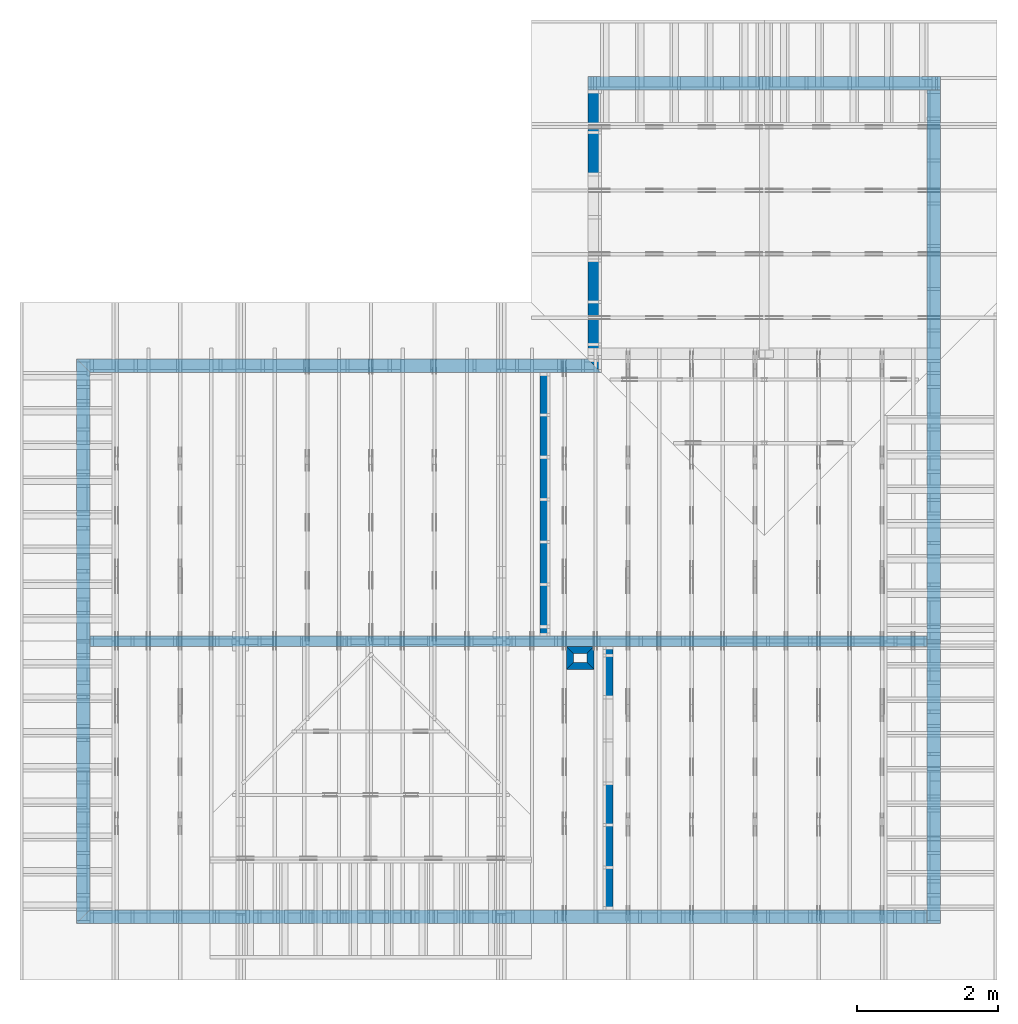
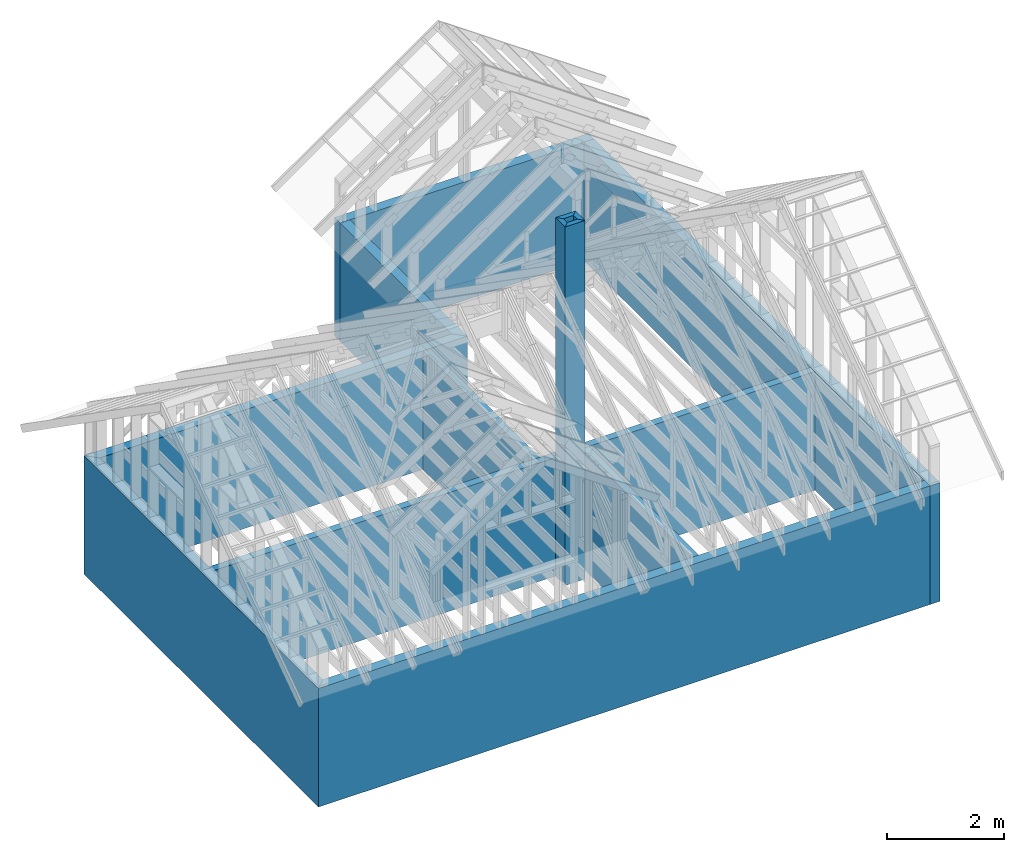
# One storey, part 1 of 70: 13 walls.
"""IFC2X3 building model written with IfcOpenShell, lengths in millimetres."""

from ifc_helpers import new_model, si_unit, frame, origin, origin_with_axes, origin_2d, place, context, project, spatial, polyline, segment, composite_curve, outline, extrude, material, layer, layer_set, layer_usage, type_object, element, save


model = new_model("IFC2X3")

# Units and contexts
model_context = context("Model", 3, precision=1e-05, world=origin())
plan_context = context("Plan", 2, precision=1e-05, world=origin_2d())
ifc_project = project(units=[si_unit("LENGTHUNIT", "METRE", prefix="MILLI"), si_unit("AREAUNIT", "SQUARE_METRE"), si_unit("VOLUMEUNIT", "CUBIC_METRE"), si_unit("SOLIDANGLEUNIT", "STERADIAN"), si_unit("PLANEANGLEUNIT", "RADIAN"), si_unit("MASSUNIT", "GRAM"), si_unit("TIMEUNIT", "SECOND"), si_unit("THERMODYNAMICTEMPERATUREUNIT", "DEGREE_CELSIUS"), si_unit("LUMINOUSINTENSITYUNIT", "LUMEN")], contexts=[model_context, plan_context])

# Site, building, storey
site_placement = place(None, origin_with_axes())
site = spatial("IfcSite", under=ifc_project, at=site_placement, CompositionType="ELEMENT")
building_placement = place(site_placement, origin_with_axes())
building = spatial("IfcBuilding", under=site, at=building_placement, Name="Layout 1", CompositionType="ELEMENT")
storey_placement = place(building_placement, origin_with_axes())
storey = spatial("IfcBuildingStorey", under=building, at=storey_placement, Name="Storey 1", CompositionType="ELEMENT", Elevation=0.0)

# Walls
ifc_material_1 = material(Name="Framing")
ifc_layer_1 = layer(ifc_material_1, 195.0)
ifc_layer_set_1 = layer_set([ifc_layer_1])
ifc_layer_usage_1 = layer_usage(ifc_layer_set_1, "AXIS2", "POSITIVE", 0.0)
wall_type_1 = type_object("IfcWallType", Name="YV195", PredefinedType="STANDARD", material=ifc_layer_set_1)
wall_1_placement = place(storey_placement, frame((-243.55339059327721, 0.0, -2470.0), z_axis=(0.0, 0.0, 1.0), x_axis=(1.0, 0.0, 0.0)))
element("IfcWallStandardCase", 1, at=wall_1_placement, inside=storey, type_object=wall_type_1, material=ifc_layer_usage_1, Name="Wall 1", context=model_context, shape_type="SweptSolid", body=[
    extrude(outline(composite_curve([segment(polyline([(195.00000000000003, 195.0), (-1.7053025658242404e-13, 2.842170943040401e-14)]), True, "CONTINUOUS"), segment(polyline([(-1.7053025658242404e-13, 2.842170943040401e-14), (12048.553390593277, 0.0)]), True, "CONTINUOUS"), segment(polyline([(12048.553390593277, 0.0), (12048.553390593277, 195.0)]), True, "CONTINUOUS"), segment(polyline([(12048.553390593277, 195.0), (195.00000000000003, 195.0)]), True, "CONTINUOUS")], self_intersect=False)), origin_with_axes(), (0.0, 0.0, 1.0), 2470.0),
])
ifc_layer_usage_2 = layer_usage(ifc_layer_set_1, "AXIS2", "POSITIVE", 0.0)
wall_2_placement = place(storey_placement, frame((12000.0, 0.0, -2470.0), z_axis=(0.0, 0.0, 1.0), x_axis=(6.123031769111886e-17, 1.0, 0.0)))
element("IfcWallStandardCase", 2, at=wall_2_placement, inside=storey, type_object=wall_type_1, material=ifc_layer_usage_2, Name="Wall 2", context=model_context, shape_type="SweptSolid", body=[
    extrude(outline(composite_curve([segment(polyline([(-1.1939911949768178e-14, 195.0), (0.0, 0.0)]), True, "CONTINUOUS"), segment(polyline([(0.0, 0.0), (11805.0, 7.228239003436582e-13)]), True, "CONTINUOUS"), segment(polyline([(11805.0, 7.228239003436582e-13), (11805.0, 195.0000000000007)]), True, "CONTINUOUS"), segment(polyline([(11805.0, 195.0000000000007), (-1.1939911949768178e-14, 195.0)]), True, "CONTINUOUS")], self_intersect=False)), origin_with_axes(), (0.0, 0.0, 1.0), 2470.0),
])
ifc_layer_usage_3 = layer_usage(ifc_layer_set_1, "AXIS2", "POSITIVE", 0.0)
wall_3_placement = place(storey_placement, frame((7000.0, 8000.0, -2470.0), z_axis=(0.0, 0.0, 1.0), x_axis=(-1.0, 1.2246063538223773e-16, 0.0)))
element("IfcWallStandardCase", 3, at=wall_3_placement, inside=storey, type_object=wall_type_1, material=ifc_layer_usage_3, Name="Wall 3", context=model_context, shape_type="SweptSolid", body=[
    extrude(outline(composite_curve([segment(polyline([(-194.99999999999912, 194.99999999999997), (9.094947017729282e-13, 1.113772990558916e-28)]), True, "CONTINUOUS"), segment(polyline([(9.094947017729282e-13, 1.113772990558916e-28), (7243.553390593276, -2.244455113571328e-14)]), True, "CONTINUOUS"), segment(polyline([(7243.553390593276, -2.244455113571328e-14), (7048.553390593276, 194.99999999999994)]), True, "CONTINUOUS"), segment(polyline([(7048.553390593276, 194.99999999999994), (-194.99999999999912, 194.99999999999997)]), True, "CONTINUOUS")], self_intersect=False)), origin_with_axes(), (0.0, 0.0, 1.0), 2470.0),
])
ifc_layer_usage_4 = layer_usage(ifc_layer_set_1, "AXIS2", "POSITIVE", 0.0)
wall_4_placement = place(storey_placement, frame((-243.55339059327576, 8000.0, -2470.0), z_axis=(0.0, 0.0, 1.0), x_axis=(-1.836909530733566e-16, -1.0, 0.0)))
element("IfcWallStandardCase", 4, at=wall_4_placement, inside=storey, type_object=wall_type_1, material=ifc_layer_usage_4, Name="Wall 4", context=model_context, shape_type="SweptSolid", body=[
    extrude(outline(composite_curve([segment(polyline([(194.99999999999906, 195.0), (-9.094947017729282e-13, -1.670659485838374e-28)]), True, "CONTINUOUS"), segment(polyline([(-9.094947017729282e-13, -1.670659485838374e-28), (8000.0, 2.002044363624833e-14)]), True, "CONTINUOUS"), segment(polyline([(8000.0, 2.002044363624833e-14), (7805.0, 195.0)]), True, "CONTINUOUS"), segment(polyline([(7805.0, 195.0), (194.99999999999906, 195.0)]), True, "CONTINUOUS")], self_intersect=False)), origin_with_axes(), (0.0, 0.0, 1.0), 2470.0),
])
ifc_layer_usage_5 = layer_usage(ifc_layer_set_1, "AXIS2", "POSITIVE", 0.0)
wall_5_placement = place(storey_placement, frame((12000.0, 12000.0, -2470.0), z_axis=(0.0, 0.0, 1.0), x_axis=(-1.0, 1.2246063538223773e-16, 0.0)))
element("IfcWallStandardCase", 5, at=wall_5_placement, inside=storey, type_object=wall_type_1, material=ifc_layer_usage_5, Name="Wall 5", context=model_context, shape_type="SweptSolid", body=[
    extrude(outline(composite_curve([segment(polyline([(-2.3879823899536357e-14, 195.0), (0.0, 0.0)]), True, "CONTINUOUS"), segment(polyline([(0.0, 0.0), (5000.0, 6.123031769111886e-13)]), True, "CONTINUOUS"), segment(polyline([(5000.0, 6.123031769111886e-13), (5000.0, 195.00000000000063)]), True, "CONTINUOUS"), segment(polyline([(5000.0, 195.00000000000063), (-2.3879823899536357e-14, 195.0)]), True, "CONTINUOUS")], self_intersect=False)), origin_with_axes(), (0.0, 0.0, 1.0), 2470.0),
])
ifc_layer_usage_6 = layer_usage(ifc_layer_set_1, "AXIS2", "POSITIVE", 0.0)
wall_6_placement = place(storey_placement, frame((7000.0, 11805.0, -2470.0), z_axis=(0.0, 0.0, 1.0), x_axis=(-1.836909530733566e-16, -1.0, 0.0)))
element("IfcWallStandardCase", 6, at=wall_6_placement, inside=storey, type_object=wall_type_1, material=ifc_layer_usage_6, Name="Wall 6", context=model_context, shape_type="SweptSolid", body=[
    extrude(outline(composite_curve([segment(polyline([(-3.5819735849304535e-14, 195.0), (0.0, 0.0)]), True, "CONTINUOUS"), segment(polyline([(0.0, 0.0), (3805.0, -2.1055062532880642e-13)]), True, "CONTINUOUS"), segment(polyline([(3805.0, -2.1055062532880642e-13), (4000.0, 194.99999999999983)]), True, "CONTINUOUS"), segment(polyline([(4000.0, 194.99999999999983), (-3.5819735849304535e-14, 195.0)]), True, "CONTINUOUS")], self_intersect=False)), origin_with_axes(), (0.0, 0.0, 1.0), 2470.0),
])
ifc_layer_2 = layer(ifc_material_1, 145.0)
ifc_layer_set_2 = layer_set([ifc_layer_2])
ifc_layer_usage_7 = layer_usage(ifc_layer_set_2, "AXIS2", "POSITIVE", -72.5)
wall_type_2 = type_object("IfcWallType", Name="IV145", PredefinedType="STANDARD", material=ifc_layer_set_2)
wall_7_placement = place(storey_placement, frame((-243.55339059327576, 4000.0000000000014, -2470.0), z_axis=(0.0, 0.0, 1.0), x_axis=(1.0, 0.0, 0.0)))
element("IfcWallStandardCase", 7, at=wall_7_placement, inside=storey, type_object=wall_type_2, material=ifc_layer_usage_7, Name="Wall 7", context=model_context, shape_type="SweptSolid", body=[
    extrude(outline(composite_curve([segment(polyline([(194.99999999999926, 72.49999999999955), (194.99999999999926, -72.50000000000045)]), True, "CONTINUOUS"), segment(polyline([(194.99999999999926, -72.50000000000045), (12048.553390593275, -72.50000000000045)]), True, "CONTINUOUS"), segment(polyline([(12048.553390593275, -72.50000000000045), (12048.553390593275, 72.5)]), True, "CONTINUOUS"), segment(polyline([(12048.553390593275, 72.5), (194.99999999999926, 72.49999999999955)]), True, "CONTINUOUS")], self_intersect=False)), origin_with_axes(), (0.0, 0.0, 1.0), 2470.0),
])
ifc_layer_usage_8 = layer_usage(ifc_layer_set_2, "AXIS2", "POSITIVE", -72.5)
wall_8_placement = place(storey_placement, frame((6392.65185546875, 8000.0, -2470.0), z_axis=(0.0, 0.0, 1.0), x_axis=(-1.836909530733566e-16, -1.0, 0.0)))
element("IfcWallStandardCase", 8, at=wall_8_placement, inside=storey, type_object=wall_type_2, material=ifc_layer_usage_8, Name="Wall 8", context=model_context, shape_type="SweptSolid", body=[
    extrude(outline(composite_curve([segment(polyline([(195.0, 72.50000000000004), (195.0, -72.49999999999996)]), True, "CONTINUOUS"), segment(polyline([(195.0, -72.49999999999996), (3927.4999999999986, -72.49999999999837)]), True, "CONTINUOUS"), segment(polyline([(3927.4999999999986, -72.49999999999837), (3927.4999999999986, 72.50000000000072)]), True, "CONTINUOUS"), segment(polyline([(3927.4999999999986, 72.50000000000072), (195.0, 72.50000000000004)]), True, "CONTINUOUS")], self_intersect=False)), origin_with_axes(), (0.0, 0.0, 1.0), 2470.0),
])
ifc_layer_usage_9 = layer_usage(ifc_layer_set_2, "AXIS2", "POSITIVE", -72.5)
wall_9_placement = place(storey_placement, frame((7286.697265625001, 0.0, -2470.0), z_axis=(0.0, 0.0, 1.0), x_axis=(6.123031769111886e-17, 1.0, 0.0)))
element("IfcWallStandardCase", 9, at=wall_9_placement, inside=storey, type_object=wall_type_2, material=ifc_layer_usage_9, Name="Wall 9", context=model_context, shape_type="SweptSolid", body=[
    extrude(outline(composite_curve([segment(polyline([(195.0, 72.50000000000001), (195.0, -72.49999999999999)]), True, "CONTINUOUS"), segment(polyline([(195.0, -72.49999999999999), (3927.500000000001, -72.49999999999976)]), True, "CONTINUOUS"), segment(polyline([(3927.500000000001, -72.49999999999976), (3927.500000000001, 72.50000000000024)]), True, "CONTINUOUS"), segment(polyline([(3927.500000000001, 72.50000000000024), (195.0, 72.50000000000001)]), True, "CONTINUOUS")], self_intersect=False)), origin_with_axes(), (0.0, 0.0, 1.0), 2470.0),
])
ifc_material_2 = material(Name="InteriorLining")
ifc_layer_3 = layer(ifc_material_2, 100.0)
ifc_layer_set_3 = layer_set([ifc_layer_3])
ifc_layer_usage_10 = layer_usage(ifc_layer_set_3, "AXIS2", "POSITIVE", 0.0)
wall_type_3 = type_object("IfcWallType", Name="Chimney 100", PredefinedType="STANDARD", material=ifc_layer_set_3)
wall_10_placement = place(storey_placement, frame((7088.750000000146, 3927.5000000000005, -2470.0), z_axis=(0.0, 0.0, 1.0), x_axis=(-1.0, 1.2246063538223773e-16, 0.0)))
element("IfcWallStandardCase", 10, at=wall_10_placement, inside=storey, type_object=wall_type_3, material=ifc_layer_usage_10, Name="Wall 10", context=model_context, shape_type="SweptSolid", body=[
    extrude(outline(composite_curve([segment(polyline([(99.99999999999999, 100.00000000000001), (0.0, 0.0)]), True, "CONTINUOUS"), segment(polyline([(0.0, 0.0), (393.75000000014643, 4.8218875181774034e-14)]), True, "CONTINUOUS"), segment(polyline([(393.75000000014643, 4.8218875181774034e-14), (293.75000000014643, 100.00000000000004)]), True, "CONTINUOUS"), segment(polyline([(293.75000000014643, 100.00000000000004), (99.99999999999999, 100.00000000000001)]), True, "CONTINUOUS")], self_intersect=False)), origin_with_axes(), (0.0, 0.0, 1.0), 7470.0),
])
ifc_layer_usage_11 = layer_usage(ifc_layer_set_3, "AXIS2", "POSITIVE", 0.0)
wall_11_placement = place(storey_placement, frame((6695.0, 3927.5000000000005, -2470.0), z_axis=(0.0, 0.0, 1.0), x_axis=(-1.836909530733566e-16, -1.0, 0.0)))
element("IfcWallStandardCase", 11, at=wall_11_placement, inside=storey, type_object=wall_type_3, material=ifc_layer_usage_11, Name="Wall 11", context=model_context, shape_type="SweptSolid", body=[
    extrude(outline(composite_curve([segment(polyline([(99.99999999999999, 100.00000000000001), (0.0, 0.0)]), True, "CONTINUOUS"), segment(polyline([(0.0, 0.0), (327.5, 6.015878713152428e-14)]), True, "CONTINUOUS"), segment(polyline([(327.5, 6.015878713152428e-14), (227.49999999999997, 100.00000000000004)]), True, "CONTINUOUS"), segment(polyline([(227.49999999999997, 100.00000000000004), (99.99999999999999, 100.00000000000001)]), True, "CONTINUOUS")], self_intersect=False)), origin_with_axes(), (0.0, 0.0, 1.0), 7470.0),
])
ifc_layer_usage_12 = layer_usage(ifc_layer_set_3, "AXIS2", "POSITIVE", 0.0)
wall_12_placement = place(storey_placement, frame((6695.0, 3600.0000000000005, -2470.0), z_axis=(0.0, 0.0, 1.0), x_axis=(1.0, 0.0, 0.0)))
element("IfcWallStandardCase", 12, at=wall_12_placement, inside=storey, type_object=wall_type_3, material=ifc_layer_usage_12, Name="Wall 12", context=model_context, shape_type="SweptSolid", body=[
    extrude(outline(composite_curve([segment(polyline([(100.0, 100.0), (0.0, 0.0)]), True, "CONTINUOUS"), segment(polyline([(0.0, 0.0), (393.75000000014643, 0.0)]), True, "CONTINUOUS"), segment(polyline([(393.75000000014643, 0.0), (293.75000000014643, 100.0)]), True, "CONTINUOUS"), segment(polyline([(293.75000000014643, 100.0), (100.0, 100.0)]), True, "CONTINUOUS")], self_intersect=False)), origin_with_axes(), (0.0, 0.0, 1.0), 7470.0),
])
ifc_layer_usage_13 = layer_usage(ifc_layer_set_3, "AXIS2", "POSITIVE", 0.0)
wall_13_placement = place(storey_placement, frame((7088.750000000146, 3600.0000000000005, -2470.0), z_axis=(0.0, 0.0, 1.0), x_axis=(6.123031769111886e-17, 1.0, 0.0)))
element("IfcWallStandardCase", 13, at=wall_13_placement, inside=storey, type_object=wall_type_3, material=ifc_layer_usage_13, Name="Wall 13", context=model_context, shape_type="SweptSolid", body=[
    extrude(outline(composite_curve([segment(polyline([(100.0, 100.0), (0.0, 0.0)]), True, "CONTINUOUS"), segment(polyline([(0.0, 0.0), (327.5, 2.0052929043841428e-14)]), True, "CONTINUOUS"), segment(polyline([(327.5, 2.0052929043841428e-14), (227.5, 100.00000000000001)]), True, "CONTINUOUS"), segment(polyline([(227.5, 100.00000000000001), (100.0, 100.0)]), True, "CONTINUOUS")], self_intersect=False)), origin_with_axes(), (0.0, 0.0, 1.0), 7470.0),
])

save(model, "model.ifc")
